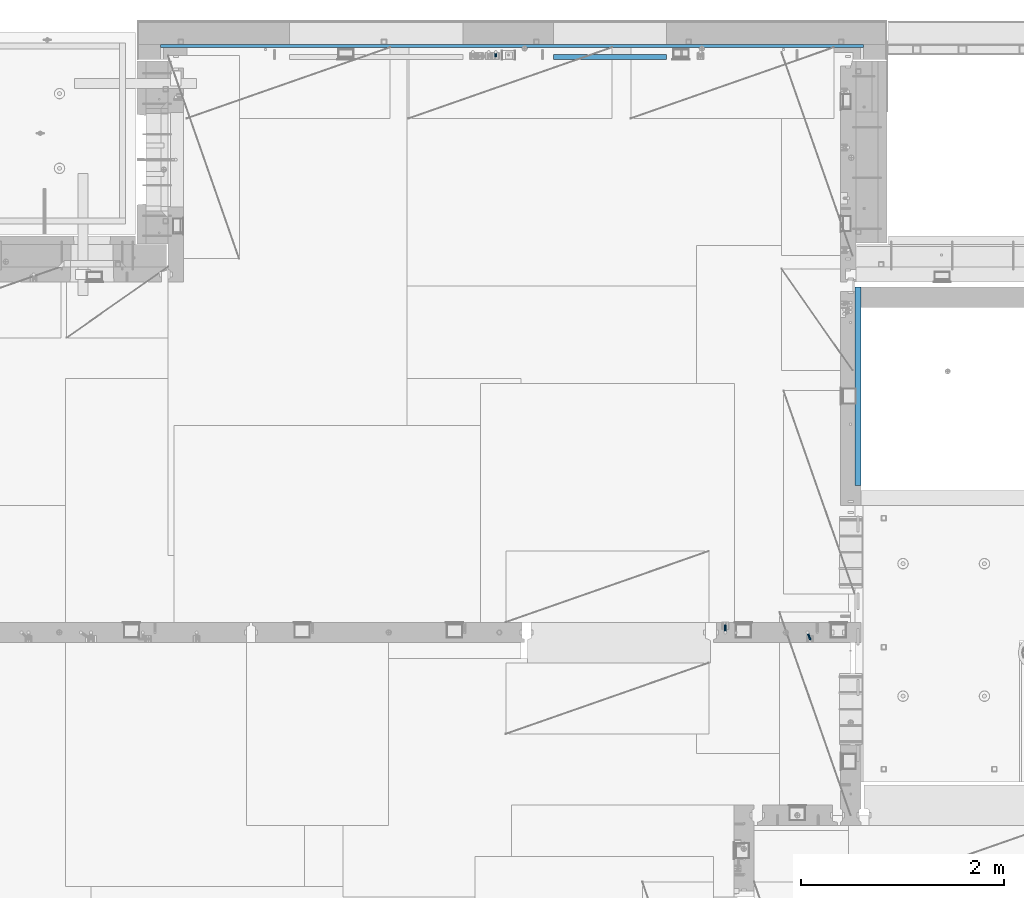
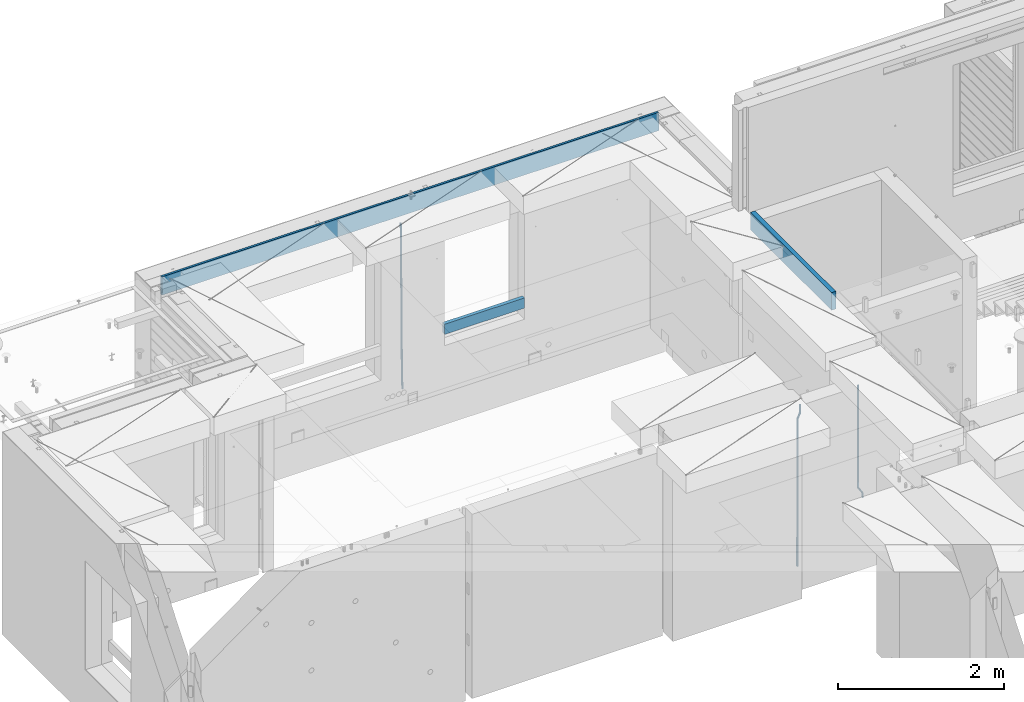
# One storey, part 118 of 350: 6 beams, 3 elements without a shape of their own.
"""IFC2X3 building model written with IfcOpenShell, lengths in millimetres."""

from ifc_helpers import new_model, si_unit, frame, origin_with_axes, place, context, subcontext, project, spatial, faceted_brep, material, type_object, element, aggregate, save


model = new_model("IFC2X3")

# Units and contexts
model_context = context("Model", 3, precision=1e-05, world=origin_with_axes())
body_context = subcontext(model_context, "Body", "Model", "MODEL_VIEW")
ifc_project = project(units=[si_unit("LENGTHUNIT", "METRE", prefix="MILLI"), si_unit("AREAUNIT", "SQUARE_METRE"), si_unit("VOLUMEUNIT", "CUBIC_METRE"), si_unit("MASSUNIT", "GRAM", prefix="KILO"), si_unit("TIMEUNIT", "SECOND"), si_unit("PLANEANGLEUNIT", "RADIAN"), si_unit("SOLIDANGLEUNIT", "STERADIAN"), si_unit("THERMODYNAMICTEMPERATUREUNIT", "DEGREE_CELSIUS"), si_unit("LUMINOUSINTENSITYUNIT", "LUMEN")], contexts=[model_context])

# Site, building, storey
site_placement = place(None, origin_with_axes())
site = spatial("IfcSite", under=ifc_project, at=site_placement, CompositionType="ELEMENT")
building_placement = place(site_placement, origin_with_axes())
building = spatial("IfcBuilding", under=site, at=building_placement, CompositionType="ELEMENT")
storey_placement = place(building_placement, origin_with_axes())
storey = spatial("IfcBuildingStorey", under=building, at=storey_placement, Name="2", CompositionType="ELEMENT", Elevation=0.0)

# Assembly, beams
assembly_1_placement = place(storey_placement, origin_with_axes())
assembly_1 = element("IfcElementAssembly", 1, at=assembly_1_placement, inside=storey, AssemblyPlace="NOTDEFINED", PredefinedType="REINFORCEMENT_UNIT")
ifc_material_1 = material()
beam_type_1 = type_object("IfcBeamType", Name="D20", PredefinedType="NOTDEFINED")
beam_1_placement = place(assembly_1_placement, frame((17285.016478657, 16980.0, 87407.5), z_axis=(-0.000415599999849952, -0.999999913638316, 0.0), x_axis=(-6.05680000062309e-05, -4.00000390151988e-09, -0.999999998165759)))
beam_1 = element("IfcBeam", 2, at=beam_1_placement, type_object=beam_type_1, material=ifc_material_1, Name="JM20", ObjectType="D20", context=body_context, shape_type="Brep", body=[
    faceted_brep([(0.000459931368823163, -9.99999998942076, 0.0), (0.000325058383168653, -7.07106780439426, -7.07106781187031), (1498.53016917036, -7.00214571310062, -7.07110244258729), (1498.53030404639, -9.93107788867201, -3.46394881489687e-05), (0.0, 0.0, -10.0), (1498.52984388257, 0.0689220912790915, -10.0000346307206), (-0.000325382832670584, 7.07106780437971, -7.07106781186667), (1498.52951872915, 7.13998989566971, -7.07110244258365), (-0.000459931412478909, 9.9999999894244, 0.0), (1498.52938418057, 10.0689220807144, -3.46307206200436e-05), (-0.000325058426824398, 7.07106780439062, 7.07106781186667), (1498.52951905355, 7.13998989568427, 7.07103318114605), (0.0, 0.0, 10.0), (1498.52984434133, 0.0689220913009194, 9.99996536927938), (0.000325382789014839, -7.07106780437607, 7.07106781186303), (1498.53016949476, -7.00214571308607, 7.07103318114241), (1512.41720874803, -5.73582294623338, -3.78448857876356), (1509.77427058959, -8.90577003658836, 2.66104918808924), (1506.12781116656, -6.30933666407145, 8.86914963737581), (1503.61387695429, 0.5325217154641, 11.203191722434), (1503.70509651935, 7.6119372551475, 8.29592524499458), (1506.34803467779, 10.7818843455061, 1.85038747814542), (1509.99449410092, 8.18545097300375, -4.35771297110477), (1512.50842831319, 1.34359259344637, -6.6917550561775), (1523.10793428493, 4.85819958866705, 2.43339327473223), (1522.94729923509, -2.24423288682374, 5.28089974098111), (1518.68801206884, 11.068066365151, 3.12656423834051), (1512.27666307625, 12.7477117054659, 6.95436248228361), (1507.62956859401, 8.91322214926913, 11.6745157093537), (1507.46893354415, 1.81078967378926, 14.5220221756208), (1511.88885576031, -4.39907710268017, 13.8288512120525), (1518.30020474852, -6.07872245333419, 10.0010529750907), (1556.47190306216, 16.2553988912259, 53.3150705600565), (1551.82480858495, 12.4209093455574, 58.0352237797015), (1556.63253811194, 23.3578313666767, 50.4675640938258), (1552.2126158958, 29.5676981431861, 51.1607350575687), (1545.80126690332, 31.2473434836029, 54.9885333017664), (1541.1541724212, 27.4128539274789, 59.7086865290003), (1540.99353737144, 20.3104214520208, 62.5561929952273), (1545.41345958759, 14.100554675515, 61.8630220314881), (1560.39637396604, 17.5567067062075, 56.6936612143036), (1557.75345399432, 14.386777545431, 63.1392152562548), (1554.10697584673, 16.9832211248868, 69.3473004384578), (1551.59299696748, 23.8250760096525, 71.6813046576062), (1551.6841720884, 30.9044764000282, 68.7739998967481), (1554.32709206025, 34.0744055607975, 62.3284458548405), (1557.97357020773, 31.4779619813417, 56.1203606726085), (1560.48754908697, 24.6361070965759, 53.7863564534418), (1565.57152260729, 25.0997628321384, 54.9895678972971), (1565.57195097132, 18.0287166318594, 57.9185522284643), (1565.57109441068, 32.1708522292429, 57.9184479422765), (1565.5709172132, 35.0998365550477, 64.9894941556158), (1565.57109481466, 32.1709565155361, 72.0605835657152), (1565.57152317863, 25.0999103152426, 74.9895678968714), (1565.5719513753, 18.0288209181526, 72.0606878518956), (1565.57212857006, 15.0998365824271, 64.9896416479532), (1617.49891294041, 18.0318617339399, 57.9185507229813), (1617.49909054188, 15.1029816944028, 64.9896401330443), (1617.49848457637, 25.1029079342443, 54.989566391796), (1617.49805637961, 32.1739973313524, 57.9184464367172), (1617.49787918197, 35.1029816571718, 64.9894926500019), (1617.49805678344, 32.1741016176347, 72.0605820600649), (1617.49848514747, 25.1030554173267, 74.9895663912539), (1617.49891334424, 18.0319660202294, 72.060686346329)], [[[0, 1, 2, 3]], [[1, 4, 5, 2]], [[4, 6, 7, 5]], [[6, 8, 9, 7]], [[8, 10, 11, 9]], [[10, 12, 13, 11]], [[12, 14, 15, 13]], [[14, 0, 3, 15]], [[14, 12, 10, 8, 6, 4, 1, 0]], [[3, 2, 16, 17]], [[15, 3, 17, 18]], [[13, 15, 18, 19]], [[11, 13, 19, 20]], [[9, 11, 20, 21]], [[7, 9, 21, 22]], [[5, 7, 22, 23]], [[2, 5, 23, 16]], [[23, 24, 25, 16]], [[22, 26, 24, 23]], [[21, 27, 26, 22]], [[20, 28, 27, 21]], [[19, 29, 28, 20]], [[18, 30, 29, 19]], [[17, 31, 30, 18]], [[16, 25, 31, 17]], [[31, 25, 32, 33]], [[25, 24, 34, 32]], [[24, 26, 35, 34]], [[26, 27, 36, 35]], [[27, 28, 37, 36]], [[28, 29, 38, 37]], [[29, 30, 39, 38]], [[30, 31, 33, 39]], [[33, 32, 40, 41]], [[39, 33, 41, 42]], [[38, 39, 42, 43]], [[37, 38, 43, 44]], [[36, 37, 44, 45]], [[35, 36, 45, 46]], [[34, 35, 46, 47]], [[32, 34, 47, 40]], [[47, 48, 49, 40]], [[46, 50, 48, 47]], [[45, 51, 50, 46]], [[44, 52, 51, 45]], [[43, 53, 52, 44]], [[42, 54, 53, 43]], [[41, 55, 54, 42]], [[40, 49, 55, 41]], [[55, 49, 56, 57]], [[49, 48, 58, 56]], [[48, 50, 59, 58]], [[50, 51, 60, 59]], [[51, 52, 61, 60]], [[52, 53, 62, 61]], [[53, 54, 63, 62]], [[54, 55, 57, 63]], [[58, 59, 60, 61, 62, 63, 57, 56]]]),
])
beam_2_placement = place(assembly_1_placement, frame((16475.016478657, 16980.0, 87407.5), z_axis=(-0.000415599999849952, -0.999999913638316, 0.0), x_axis=(-6.05680000062309e-05, -4.00000390151988e-09, -0.999999998165759)))
beam_2 = element("IfcBeam", 3, at=beam_2_placement, type_object=beam_type_1, material=ifc_material_1, Name="JM20", ObjectType="D20", context=body_context, shape_type="Brep", body=[
    faceted_brep([(-0.00060564729210455, -9.99999998165731, 0.0), (-0.000428079845733009, -7.07106779890455, -7.07106781186667), (109.663992146438, -7.07770969181365, -7.07106505070624), (109.663814574931, -10.0066418742208, 2.76014907285571e-06), (0.0, 0.0, -10.0), (109.664420484245, -0.00664189292001538, -9.99999723883957), (0.00042843479604926, 7.07106779888636, -7.07106781186303), (109.66484867355, 7.0644259059809, -7.07106505070988), (0.00060564729210455, 9.99999998166459, 3.63797880709171e-12), (109.665025886861, 9.99335808875549, 2.76115679298528e-06), (0.000428079845733009, 7.07106779890819, 7.07106781186667), (109.664848315049, 7.06442590600273, 7.07107057301982), (0.0, 0.0, 10.0), (109.664419977242, -0.00664189288727357, 10.0000027611604), (-0.000428434810601175, -7.07106779888272, 7.07106781186667), (109.663991787937, -7.07770969179182, 7.07107057302346), (123.019465653822, -0.00769783093346632, 8.49481275451399), (122.368218641306, 7.06342149385819, 5.63932810477127), (120.794596020874, 9.9924781119953, -1.25436342694593), (119.220404581531, 7.06367038153257, -8.14803083615698), (118.567784318744, -0.00734585062309634, -11.0034572490222), (119.219031331319, -7.07846517541839, -8.14797259927946), (120.79265395175, -10.0075217935628, -1.25428106757317), (122.366845391021, -7.07871406308914, 5.63938634164515), (134.432358609134, -7.0801380724879, 1.41616492140383), (135.704448506891, -0.00919495208290755, 4.05476198080942), (131.363125973905, -10.0087693538771, -4.95420191149606), (128.294665451453, -7.07953630984775, -11.3246640276848), (127.024439601548, -0.00834393120385357, -13.9634911148387), (128.296529499246, 7.06259918918295, -11.3248940553931), (131.365762135116, 9.99123047017565, -4.95452722118716), (134.434222657001, 7.06199742654644, 1.41593489364823), (232.333181448281, -7.09406463311461, -61.4435769522424), (235.401641971155, -10.0232976755033, -55.0731148385494), (231.062955598129, -0.0228722546671634, -64.0824040398293), (232.335045495653, 7.04807086590154, -61.4438069808093), (235.404278131435, 9.97670214732716, -55.0734401467271), (238.472738653494, 7.0474691041527, -48.7029780316807), (239.742964503646, -0.0237232742911146, -46.0641509440975), (238.470874606137, -7.09466639485981, -48.7027480031138), (248.152386176487, -0.0244396446978499, -49.0133708264948), (247.497266945589, 7.04670033489674, -51.8679184167595), (245.915123067214, 9.97580676374491, -58.7596380886316), (244.332752967632, 7.04704882145597, -65.6514539264135), (243.677087590491, -0.0239468102772662, -68.5062336817027), (244.33220682136, -7.09508678989368, -65.651686091438), (245.914350699837, -10.0241932187346, -58.7599664195659), (247.496720799376, -7.09543527645292, -51.8681505817658), (256.999396693936, -7.09531210125351, -52.9566469665442), (257.006072236094, -0.0243248818260327, -50.0275278254703), (256.982439129002, -10.0240497531304, -60.0277750206151), (256.965133057005, -7.09492303985826, -67.0987410777925), (256.957616135987, -0.0237746659149707, -70.0274691179584), (256.964291678203, 7.04721255350523, -67.0983499769027), (256.981249241362, 9.97595020465087, -60.027221921624), (256.998555315135, 7.04682349210998, -52.9562558656398), (2308.84129044529, -6.97271028710384, -72.0700484847293), (2308.85859651901, -9.9018369995174, -64.9990824287343), (2308.83377352433, 0.0984380867485015, -74.9987765249425), (2308.84044906651, 7.16942530619053, -72.0696573839123), (2308.85740662973, 10.0981629574344, -64.9985293286554), (2308.87471270347, 7.16903624502447, -57.9275632726531), (2308.88222962443, 0.0978878711684956, -54.9988352324472), (2308.87555408225, -6.9730993482699, -57.9279543734738), (2309.36197244871, -6.97267927451685, -72.0713099986351), (2309.37071429225, -9.90180649703325, -65.000323193126), (2309.3579998037, 0.0984693104364851, -75.0000466259553), (2309.3611234788, 7.16945631832277, -72.0709188794244), (2309.36951366749, 10.0981934592819, -64.9997700670392), (2309.37825551104, 7.16906623676914, -57.9287832615337), (2309.38222815606, 0.0979176518158056, -55.0000466342135), (2309.37910448095, -6.97306935607776, -57.929174380748), (2309.8826559803, -6.97264773775169, -72.0713100117428), (2309.88283356852, -9.90177547898566, -65.0003232060189), (2309.88222762165, 0.0985010618751403, -75.0000466391502), (2309.88179941924, 7.16948785463319, -72.0709188925321), (2309.88162220824, 10.0982244766819, -64.9997700799322), (2309.88179979647, 7.16909673544797, -57.9287832742084), (2309.88222815514, 0.0979479358211393, -55.0000466468009), (2309.88265635754, -6.97303885693691, -57.9291743934191), (2417.50042500655, -6.96612954309967, -72.0713127206036), (2417.50060259478, -9.89525728433364, -65.0003259148798), (2417.49999664789, 0.105019256523519, -75.0000493480147), (2417.49956844548, 7.17600604928157, -72.0709216013965), (2417.49939123449, 10.1047426713303, -64.9997727887931), (2417.49956882271, 7.17561493009634, -57.9287859830729), (2417.49999718138, 0.104466130473156, -55.0000493556618), (2417.50042538378, -6.96652066228489, -57.9291771022799)], [[[0, 1, 2, 3]], [[1, 4, 5, 2]], [[4, 6, 7, 5]], [[6, 8, 9, 7]], [[8, 10, 11, 9]], [[10, 12, 13, 11]], [[12, 14, 15, 13]], [[14, 0, 3, 15]], [[14, 12, 10, 8, 6, 4, 1, 0]], [[11, 13, 16, 17]], [[9, 11, 17, 18]], [[7, 9, 18, 19]], [[5, 7, 19, 20]], [[2, 5, 20, 21]], [[3, 2, 21, 22]], [[15, 3, 22, 23]], [[13, 15, 23, 16]], [[23, 24, 25, 16]], [[22, 26, 24, 23]], [[21, 27, 26, 22]], [[20, 28, 27, 21]], [[19, 29, 28, 20]], [[18, 30, 29, 19]], [[17, 31, 30, 18]], [[16, 25, 31, 17]], [[26, 27, 32, 33]], [[27, 28, 34, 32]], [[28, 29, 35, 34]], [[29, 30, 36, 35]], [[30, 31, 37, 36]], [[31, 25, 38, 37]], [[25, 24, 39, 38]], [[24, 26, 33, 39]], [[37, 38, 40, 41]], [[36, 37, 41, 42]], [[35, 36, 42, 43]], [[34, 35, 43, 44]], [[32, 34, 44, 45]], [[33, 32, 45, 46]], [[39, 33, 46, 47]], [[38, 39, 47, 40]], [[47, 48, 49, 40]], [[46, 50, 48, 47]], [[45, 51, 50, 46]], [[44, 52, 51, 45]], [[43, 53, 52, 44]], [[42, 54, 53, 43]], [[41, 55, 54, 42]], [[40, 49, 55, 41]], [[50, 51, 56, 57]], [[51, 52, 58, 56]], [[52, 53, 59, 58]], [[53, 54, 60, 59]], [[54, 55, 61, 60]], [[55, 49, 62, 61]], [[49, 48, 63, 62]], [[48, 50, 57, 63]], [[57, 56, 64, 65]], [[56, 58, 66, 64]], [[58, 59, 67, 66]], [[59, 60, 68, 67]], [[60, 61, 69, 68]], [[61, 62, 70, 69]], [[62, 63, 71, 70]], [[63, 57, 65, 71]], [[65, 64, 72, 73]], [[64, 66, 74, 72]], [[66, 67, 75, 74]], [[67, 68, 76, 75]], [[68, 69, 77, 76]], [[69, 70, 78, 77]], [[70, 71, 79, 78]], [[71, 65, 73, 79]], [[73, 72, 80, 81]], [[72, 74, 82, 80]], [[74, 75, 83, 82]], [[75, 76, 84, 83]], [[76, 77, 85, 84]], [[77, 78, 86, 85]], [[78, 79, 87, 86]], [[79, 73, 81, 87]], [[82, 83, 84, 85, 86, 87, 81, 80]]]),
])
aggregate(assembly_1, [beam_1, beam_2])

# Assembly, beam
assembly_2_placement = place(storey_placement, origin_with_axes())
assembly_2 = element("IfcElementAssembly", 4, at=assembly_2_placement, inside=storey, AssemblyPlace="NOTDEFINED", PredefinedType="REINFORCEMENT_UNIT")
ifc_material_2 = material(Name="CONCRETE/C25/30")
beam_type_2 = type_object("IfcBeamType", Name="260X60", PredefinedType="NOTDEFINED")
beam_3_placement = place(assembly_2_placement, frame((17779.9999105288, 18424.9992663657, 87600.0), z_axis=(0.0, 0.0, 1.0), x_axis=(0.0, 1.0, 0.0)))
beam_3 = element("IfcBeam", 5, at=beam_3_placement, type_object=beam_type_2, material=ifc_material_2, ObjectType="260X60", context=body_context, shape_type="Brep", body=[
    faceted_brep([(0.0, 30.0, -130.0), (0.0, 30.0, 130.0), (1954.9989445891, 30.0, 130.0), (1954.9989445891, 30.0, -130.0), (0.0, -30.0, 130.0), (1954.9989445891, -30.0, 130.0), (0.0, -30.0, -130.0), (1954.9989445891, -30.0, -130.0)], [[[0, 1, 2, 3]], [[1, 4, 5, 2]], [[4, 6, 7, 5]], [[6, 0, 3, 7]], [[5, 7, 3, 2]], [[6, 4, 1, 0]]]),
])
aggregate(assembly_2, [beam_3])

# Assembly, beams
assembly_3_placement = place(storey_placement, origin_with_axes())
assembly_3 = element("IfcElementAssembly", 6, at=assembly_3_placement, inside=storey, AssemblyPlace="NOTDEFINED", PredefinedType="REINFORCEMENT_UNIT")
beam_type_3 = type_object("IfcBeamType", Name="D25", PredefinedType="NOTDEFINED")
beam_4_placement = place(assembly_3_placement, frame((14215.0000000039, 22654.9999977209, 84990.0), z_axis=(-0.000205762999925498, 0.999642804629538, -0.0267249099901004), x_axis=(4.30000201928125e-08, 0.0267249099948059, 0.999642825806181)))
beam_4 = element("IfcBeam", 7, at=beam_4_placement, type_object=beam_type_3, material=ifc_material_1, Name="JM25", ObjectType="D25", context=body_context, shape_type="Brep", body=[
    faceted_brep([(-7.41420080885291e-08, -12.5, -3.63797880709171e-12), (-6.42030499875546e-08, -10.8253175473074, -6.25000000000364), (60.4103898235917, -10.8253175318459, -6.2499999938409), (60.4103898269532, -12.4999999845422, 6.16273609921336e-09), (-3.70782800018787e-08, -6.25000000000364, -10.8253175473074), (60.4103898202884, -6.24999998454587, -10.8253175411446), (-1.45519152283669e-11, -3.63797880709171e-12, -12.5), (60.4103898179019, 1.54577719513327e-08, -12.4999999938373), (3.70637280866504e-08, 6.25, -10.8253175473074), (60.410389817087, 6.25000001545777, -10.825317541141), (6.42030499875546e-08, 10.8253175473001, -6.25000000000364), (60.410389818062, 10.8253175627578, -6.24999999383726), (7.41420080885291e-08, 12.4999999999927, 0.0), (60.4103898205503, 12.5000000154541, 6.16273609921336e-09), (6.42176019027829e-08, 10.8253175473001, 6.24999999999636), (60.4103898238973, 10.8253175627651, 6.2500000061591), (3.70928319171071e-08, 6.24999999999636, 10.8253175473037), (60.4103898272151, 6.25000001546141, 10.8253175534664), (1.45519152283669e-11, -3.63797880709171e-12, 12.4999999999964), (60.4103898296162, 1.54541339725256e-08, 12.5000000061591), (-3.7049176171422e-08, -6.25000000000364, 10.8253175473001), (60.4103898304165, -6.24999998454587, 10.8253175534701), (-6.41884980723262e-08, -10.8253175473074, 6.25), (60.4103898294561, -10.8253175318459, 6.25000000616637), (61.0324985728803, -10.8253175316895, -6.24999999377542), (60.991802792938, -12.4999999843931, 6.22458173893392e-09), (61.0622854283865, -6.24999998437852, -10.8253175410755), (61.0731819955545, 1.5628756955266e-08, -12.4999999937718), (61.0622685480339, 6.25000001562512, -10.8253175410791), (61.032469335245, 10.8253175629216, -6.24999999377178), (60.9917690322181, 12.5000000156033, 6.22458173893392e-09), (60.9510732522613, 10.8253175629034, 6.25000000621731), (60.9212863967696, 6.25000001558874, 10.8253175535247), (60.9103898296162, 1.55814632307738e-08, 12.5000000062137), (60.9213032771368, -6.24999998441126, 10.8253175535174), (60.9511024898966, -10.8253175317113, 6.25000000621731), (61.6545545670233, -10.8253158516927, -6.24189838219536), (61.573166454793, -12.499998414296, 0.00757164385504439), (61.7141257553885, -6.24999822394238, -10.8168280205282), (61.7359179680789, 1.80548886419274e-06, -12.491368569139), (61.7140919992817, 6.25000177601396, -10.8168282403167), (61.6544960997562, 10.8253192428383, -6.2418987628771), (61.5730989426083, 12.5000015856094, 0.0075712042817031), (61.4917108303925, 10.8253190230062, 6.25704123032847), (61.4321396420273, 6.25000139525582, 10.8319708686649), (61.4103474293224, 1.36582457344048e-06, 12.5065114172721), (61.4321733981196, -6.24999860470052, 10.8319710884571), (61.4917692976451, -10.8253160715249, 6.25704161101385), (176.524302641745, -10.8250056210964, -4.74584321979273), (176.442914529529, -12.4996881836996, 1.50362680625403), (176.583873830095, -6.24968799334965, -9.3207728581292), (176.605666042786, 0.000312036081595579, -10.9953134067364), (176.583840074018, 6.25031200660669, -9.32077307791769), (176.524244174492, 10.8256294734347, -4.74584360047811), (176.44284701733, 12.5003118162058, 1.50362636668069), (176.361458905099, 10.8256292535989, 7.75309639272746), (176.301887716749, 6.25031162585219, 12.3280260310676), (176.280095504058, 0.000311596420942806, 14.0025665796711), (176.301921472827, -6.24968837410415, 12.3280262508561), (176.361517372367, -10.8250058409321, 7.75309677341284), (177.085397012124, -10.8250041057399, -4.73853556792164), (176.983633547483, -12.4996867233749, 1.51066909103247), (177.159881729676, -6.24968643771717, -9.31327097355097), (177.187129580227, 0.000313606451527448, -10.987740468332), (177.159839524218, 6.25031356221734, -9.31327130338468), (177.085323910098, 10.8256309887511, -4.73853613920801), (176.983549136537, 12.5003132764905, 1.51066843136869), (176.881785671867, 10.8256306588555, 7.7598730903228), (176.80730095433, 6.25031299082912, 12.3346084959521), (176.780053103794, 0.000312946667690994, 14.0090779907332), (176.807343159802, -6.2496870091054, 12.3346088257895), (176.881858773908, -10.8250044356355, 7.7598736616128), (177.646431799818, -10.8250018318176, -4.72756919822132), (177.524295146417, -12.4996845320202, 1.52123723245313), (177.735828462886, -6.24968410334986, -9.30201312475765), (177.768531371941, 0.00031596292683389, -10.9763759912421), (177.735777808921, 6.25031589654827, -9.30201361973741), (177.646344064575, 10.8256332626152, -4.72757005553649), (177.524193838486, 12.5003154677688, 1.52123624250817), (177.402057185071, 10.8256327675663, 7.77004267317898), (177.312660521988, 6.2503150390985, 12.3444865997226), (177.279957612933, 0.00031497282179771, 14.0188494661961), (177.312711175953, -6.24968496079964, 12.3444870946951), (177.402144920314, -10.8250023268702, 7.77004353049415), (299.377443161706, -10.8245084454466, -2.34813158632096), (299.255306508276, -12.4991911456491, 3.90067484435349), (299.466839824803, -6.24919071697514, -6.92257551286093), (299.499542733873, 0.0008093492979242, -8.59693837933446), (299.466789170867, 6.250809282923, -6.92257600783341), (299.377355426492, 10.8261266489935, -2.34813244364341), (299.255205200388, 12.5008088541435, 3.90067385440125), (299.133068546944, 10.826126153941, 10.1494802850757), (299.043671883861, 6.25080842546959, 14.7239242116229), (299.010968974762, 0.000808359200163977, 16.3982870780892), (299.043722537797, -6.24919157442127, 14.7239247065918), (299.133156282158, -10.8245089404954, 10.1494811423981), (299.98561436501, -10.8245059804758, -2.33624385599614), (299.97179243555, -12.4991882411778, 3.91467976726199), (299.995742293278, -6.24918857328521, -6.91223722345239), (299.999447243041, 0.000811375455668895, -8.58716690387519), (299.995736475976, 6.25081142679483, -6.91223684201032), (299.985604289133, 10.8261291142808, -2.33624319533556), (299.971750386685, 12.5008117588586, 3.91467993563856), (299.957928457196, 10.8261294971744, 10.1656035610831), (299.947800528913, 6.25081208998381, 14.7415969285394), (299.944095579151, 0.00081214124293183, 16.4165266089549), (299.947806346216, -6.24918791008895, 14.7415965471009), (299.957938533058, -10.8245055975785, 10.1656029004225), (300.593832239858, -10.8245078794353, -2.34543881707941), (300.688302931099, -12.4991904788549, 3.90384712594823), (300.524685350189, -6.24919022474205, -6.92023371784308), (300.499390115292, 0.000809814544481924, -8.59472497713432), (300.524724372954, 6.25080977519247, -6.92023401429469), (300.593899829313, 10.8261272150703, -2.34543933054374), (300.688380976673, 12.5008095210287, 3.90384653304136), (300.782851667915, 10.8261269216127, 10.1531324760799), (300.851998557599, 6.25080926691589, 14.7279273768363), (300.877293792495, 0.000809227632998955, 16.4024186361276), (300.851959534804, -6.24919073302226, 14.7279276732806), (300.782784078474, -10.8245081728965, 10.153132989537), (2293.32930409742, -10.8307295605009, -32.4713622331001), (2293.42377478865, -12.5054121599169, -26.2220762900724), (2293.26015720774, -6.2554119058077, -37.0461571338565), (2293.23486197284, -0.00541186651753378, -38.7206483931477), (2293.26019623051, 6.24458809413409, -37.0461574303008), (2293.32937168686, 10.8199055340046, -32.4713627465644), (2293.42385283421, 12.4945878399631, -26.2220768829684), (2293.51832352545, 10.8199052405434, -19.972790939948), (2293.58747041514, 6.24458758585388, -15.3979960391844), (2293.61276565003, -0.00541245343265473, -13.7235047798931), (2293.58743139236, -6.25541241408428, -15.3979957427327), (2293.51825593603, -10.8307298539585, -19.9727904264691), (2294.0420846676, -10.8307317859326, -32.4821379598216), (2294.03681932652, -12.5054140739521, -26.2313442200393), (2294.06778164886, -6.2554144273563, -37.0583666982457), (2294.10702478497, -0.00541458957013674, -38.7338336404937), (2294.14929890928, 6.24458531819619, -37.0595987724118), (2294.18327670435, 10.8199028679592, -32.4842719748667), (2294.1998538474, 12.4945854171456, -26.2338083683717), (2294.19458850632, 10.819903129126, -19.9830146285858), (2294.16889152506, 6.24458577054975, -15.4067858901581), (2294.12964838895, -0.0054140672327776, -13.7313189479173), (2294.08737426462, -6.2554139749991, -15.4055538159919), (2294.05339646956, -10.8307315247621, -19.9808806135297), (2294.75482297382, -10.84002603931, -32.4726521173216), (2294.64982751427, -12.513407826169, -26.2231856868602), (2294.87535820232, -6.26594539088183, -37.0476186524102), (2294.97913588268, -0.0167870967634371, -38.7222267036377), (2295.0383488692, 6.23299192477134, -37.0477663960555), (2295.03713108998, 10.8087684320271, -32.4729080168181), (2294.97580884799, 12.4844668051373, -26.2234811741473), (2294.87081338844, 10.8110850182784, -19.9740147436787), (2294.7502781599, 6.23700436985018, -15.3990482086047), (2294.64650047956, -0.0121539242718427, -13.7244401573698), (2294.58728749304, -6.26193294580662, -15.3989004649666), (2294.58850527227, -10.8377094530588, -19.9737588441894), (2316.44667268227, -11.1228921988077, -32.1839550346631), (2316.34167722271, -12.7962739856739, -25.9344886042054), (2316.56720791078, -6.54881155039038, -36.7589215697517), (2316.67098559113, -0.299653256264719, -38.4335296209792), (2316.73019857766, 5.95012576527006, -36.759069313397), (2316.72898079845, 10.5259022725259, -32.1842109341669), (2316.66765855643, 12.2016006456361, -25.9347840914961), (2316.56266309689, 10.5282188587698, -19.6853176610275), (2316.44212786836, 5.95413821035254, -15.1103511259389), (2316.33835018802, -0.295020083769487, -13.4357430747186), (2316.27913720149, -6.54479910530426, -15.1102033823008), (2316.28035498071, -11.1205756125637, -19.685061761531), (2317.13234804722, -11.1318335458927, -32.1748293731798), (2317.04181141085, -12.8054038787741, -25.9251705100723), (2317.2154741603, -6.5572650749491, -36.7502937866229), (2317.26891617525, -0.307450393454928, -38.4255717558117), (2317.27835434731, 5.94297770185585, -36.7517739018112), (2317.24125972588, 10.5192220504723, -32.1773930078925), (2317.16757178486, 12.1950816748285, -25.9281307404563), (2317.0770351485, 10.5215113419545, -19.6784718773561), (2316.99390903539, 5.94694287101083, -15.1030074639057), (2316.94046702047, -0.302871810494253, -13.4277294947169), (2316.9310288484, -6.55329990579412, -15.1015273487101), (2316.96812346982, -11.1295442544142, -19.6759082426288), (2317.81808136747, -11.1298054502913, -32.1659056455355), (2317.74200467508, -12.803315894289, -25.9160547315114), (2317.86379538118, -6.55536082026447, -36.7418676070083), (2317.8668976831, -0.305700748642266, -38.417815303761), (2317.82655701396, 5.94458339541234, -36.7446799039099), (2317.75358262347, 10.5207330230332, -32.1707766866384), (2317.66752794063, 12.1965725370646, -25.9216793252963), (2317.59145124823, 10.5230620930706, -19.6718284112721), (2317.54573723453, 5.94861746304377, -15.0958664497994), (2317.54263493262, -0.301042608574789, -13.4199187530394), (2317.58297560175, -6.55132675263303, -15.0930541529051), (2317.65594999224, -11.1274763802539, -19.6669573701693), (2417.81884292323, -10.831603083323, -30.8687911350135), (2417.74276623082, -12.505113527317, -24.618940220982), (2417.86455693691, -6.25715845329614, -35.4447530964935), (2417.86765923884, -0.00749838167394046, -37.1207007932499), (2417.82731856969, 6.24278576237703, -35.4475653933878), (2417.75434417921, 10.8189353900088, -30.8736621761236), (2417.66828949639, 12.494774904033, -24.6245648147851), (2417.59221280397, 10.8212644600353, -18.3747139007501), (2417.54649879028, 6.2468198300121, -13.79875193927), (2417.54339648837, -0.00284024161010166, -12.1228042425173), (2417.5837371575, -6.25312438566107, -13.795939642383), (2417.65671154798, -10.8292740132893, -18.3698428596399)], [[[0, 1, 2, 3]], [[1, 4, 5, 2]], [[4, 6, 7, 5]], [[6, 8, 9, 7]], [[8, 10, 11, 9]], [[10, 12, 13, 11]], [[12, 14, 15, 13]], [[14, 16, 17, 15]], [[16, 18, 19, 17]], [[18, 20, 21, 19]], [[20, 22, 23, 21]], [[22, 0, 3, 23]], [[22, 20, 18, 16, 14, 12, 10, 8, 6, 4, 1, 0]], [[3, 2, 24, 25]], [[2, 5, 26, 24]], [[5, 7, 27, 26]], [[7, 9, 28, 27]], [[9, 11, 29, 28]], [[11, 13, 30, 29]], [[13, 15, 31, 30]], [[15, 17, 32, 31]], [[17, 19, 33, 32]], [[19, 21, 34, 33]], [[21, 23, 35, 34]], [[23, 3, 25, 35]], [[25, 24, 36, 37]], [[24, 26, 38, 36]], [[26, 27, 39, 38]], [[27, 28, 40, 39]], [[28, 29, 41, 40]], [[29, 30, 42, 41]], [[30, 31, 43, 42]], [[31, 32, 44, 43]], [[32, 33, 45, 44]], [[33, 34, 46, 45]], [[34, 35, 47, 46]], [[35, 25, 37, 47]], [[37, 36, 48, 49]], [[36, 38, 50, 48]], [[38, 39, 51, 50]], [[39, 40, 52, 51]], [[40, 41, 53, 52]], [[41, 42, 54, 53]], [[42, 43, 55, 54]], [[43, 44, 56, 55]], [[44, 45, 57, 56]], [[45, 46, 58, 57]], [[46, 47, 59, 58]], [[47, 37, 49, 59]], [[49, 48, 60, 61]], [[48, 50, 62, 60]], [[50, 51, 63, 62]], [[51, 52, 64, 63]], [[52, 53, 65, 64]], [[53, 54, 66, 65]], [[54, 55, 67, 66]], [[55, 56, 68, 67]], [[56, 57, 69, 68]], [[57, 58, 70, 69]], [[58, 59, 71, 70]], [[59, 49, 61, 71]], [[61, 60, 72, 73]], [[60, 62, 74, 72]], [[62, 63, 75, 74]], [[63, 64, 76, 75]], [[64, 65, 77, 76]], [[65, 66, 78, 77]], [[66, 67, 79, 78]], [[67, 68, 80, 79]], [[68, 69, 81, 80]], [[69, 70, 82, 81]], [[70, 71, 83, 82]], [[71, 61, 73, 83]], [[73, 72, 84, 85]], [[72, 74, 86, 84]], [[74, 75, 87, 86]], [[75, 76, 88, 87]], [[76, 77, 89, 88]], [[77, 78, 90, 89]], [[78, 79, 91, 90]], [[79, 80, 92, 91]], [[80, 81, 93, 92]], [[81, 82, 94, 93]], [[82, 83, 95, 94]], [[83, 73, 85, 95]], [[85, 84, 96, 97]], [[84, 86, 98, 96]], [[86, 87, 99, 98]], [[87, 88, 100, 99]], [[88, 89, 101, 100]], [[89, 90, 102, 101]], [[90, 91, 103, 102]], [[91, 92, 104, 103]], [[92, 93, 105, 104]], [[93, 94, 106, 105]], [[94, 95, 107, 106]], [[95, 85, 97, 107]], [[97, 96, 108, 109]], [[96, 98, 110, 108]], [[98, 99, 111, 110]], [[99, 100, 112, 111]], [[100, 101, 113, 112]], [[101, 102, 114, 113]], [[102, 103, 115, 114]], [[103, 104, 116, 115]], [[104, 105, 117, 116]], [[105, 106, 118, 117]], [[106, 107, 119, 118]], [[107, 97, 109, 119]], [[109, 108, 120, 121]], [[108, 110, 122, 120]], [[110, 111, 123, 122]], [[111, 112, 124, 123]], [[112, 113, 125, 124]], [[113, 114, 126, 125]], [[114, 115, 127, 126]], [[115, 116, 128, 127]], [[116, 117, 129, 128]], [[117, 118, 130, 129]], [[118, 119, 131, 130]], [[119, 109, 121, 131]], [[121, 120, 132, 133]], [[120, 122, 134, 132]], [[122, 123, 135, 134]], [[123, 124, 136, 135]], [[124, 125, 137, 136]], [[125, 126, 138, 137]], [[126, 127, 139, 138]], [[127, 128, 140, 139]], [[128, 129, 141, 140]], [[129, 130, 142, 141]], [[130, 131, 143, 142]], [[131, 121, 133, 143]], [[133, 132, 144, 145]], [[132, 134, 146, 144]], [[134, 135, 147, 146]], [[135, 136, 148, 147]], [[136, 137, 149, 148]], [[137, 138, 150, 149]], [[138, 139, 151, 150]], [[139, 140, 152, 151]], [[140, 141, 153, 152]], [[141, 142, 154, 153]], [[142, 143, 155, 154]], [[143, 133, 145, 155]], [[145, 144, 156, 157]], [[144, 146, 158, 156]], [[146, 147, 159, 158]], [[147, 148, 160, 159]], [[148, 149, 161, 160]], [[149, 150, 162, 161]], [[150, 151, 163, 162]], [[151, 152, 164, 163]], [[152, 153, 165, 164]], [[153, 154, 166, 165]], [[154, 155, 167, 166]], [[155, 145, 157, 167]], [[157, 156, 168, 169]], [[156, 158, 170, 168]], [[158, 159, 171, 170]], [[159, 160, 172, 171]], [[160, 161, 173, 172]], [[161, 162, 174, 173]], [[162, 163, 175, 174]], [[163, 164, 176, 175]], [[164, 165, 177, 176]], [[165, 166, 178, 177]], [[166, 167, 179, 178]], [[167, 157, 169, 179]], [[169, 168, 180, 181]], [[168, 170, 182, 180]], [[170, 171, 183, 182]], [[171, 172, 184, 183]], [[172, 173, 185, 184]], [[173, 174, 186, 185]], [[174, 175, 187, 186]], [[175, 176, 188, 187]], [[176, 177, 189, 188]], [[177, 178, 190, 189]], [[178, 179, 191, 190]], [[179, 169, 181, 191]], [[181, 180, 192, 193]], [[180, 182, 194, 192]], [[182, 183, 195, 194]], [[183, 184, 196, 195]], [[184, 185, 197, 196]], [[185, 186, 198, 197]], [[186, 187, 199, 198]], [[187, 188, 200, 199]], [[188, 189, 201, 200]], [[189, 190, 202, 201]], [[190, 191, 203, 202]], [[191, 181, 193, 203]], [[194, 195, 196, 197, 198, 199, 200, 201, 202, 203, 193, 192]]]),
])
ifc_material_3 = material(Name="TIMBER/T24")
beam_type_4 = type_object("IfcBeamType", PredefinedType="NOTDEFINED")
beam_5_placement = place(assembly_3_placement, frame((15895.0002989914, 22644.9998418812, 85685.0), z_axis=(0.0, 0.0, 1.0), x_axis=(-1.0, 3.00000001838171e-08, 0.0)))
beam_5 = element("IfcBeam", 8, at=beam_5_placement, type_object=beam_type_4, material=ifc_material_3, context=body_context, shape_type="Brep", body=[
    faceted_brep([(-3.63797880709171e-12, 24.9999999999964, -75.0), (-3.63797880709171e-12, 24.9999999999964, 75.0), (1110.0, 24.9999999999964, 75.0), (1110.0, 24.9999999999964, -75.0), (0.0, -25.0000000000073, 75.0), (1110.0, -25.0000000000073, 75.0), (0.0, -25.0000000000073, -75.0), (1110.0, -25.0000000000073, -75.0)], [[[0, 1, 2, 3]], [[1, 4, 5, 2]], [[4, 6, 7, 5]], [[6, 0, 3, 7]], [[5, 7, 3, 2]], [[6, 4, 1, 0]]]),
])
beam_type_5 = type_object("IfcBeamType", Name="270X30", PredefinedType="NOTDEFINED")
beam_6_placement = place(assembly_3_placement, frame((17835.0, 22755.0, 87605.0), z_axis=(0.0, 0.0, 1.0), x_axis=(-1.0, 3.00000001838171e-08, 0.0)))
beam_6 = element("IfcBeam", 9, at=beam_6_placement, type_object=beam_type_5, material=ifc_material_2, ObjectType="270X30", context=body_context, shape_type="Brep", body=[
    faceted_brep([(0.0, 15.0, -135.0), (0.0, 15.0, 135.0), (6920.00000000003, 15.0, 135.0), (6920.00000000003, 15.0, -135.0), (0.0, -15.0, 135.0), (6920.00000000003, -15.0, 135.0), (0.0, -15.0, -135.0), (6920.00000000003, -15.0, -135.0)], [[[0, 1, 2, 3]], [[1, 4, 5, 2]], [[4, 6, 7, 5]], [[6, 0, 3, 7]], [[5, 7, 3, 2]], [[6, 4, 1, 0]]]),
])
aggregate(assembly_3, [beam_4, beam_5, beam_6])

save(model, "model.ifc")
